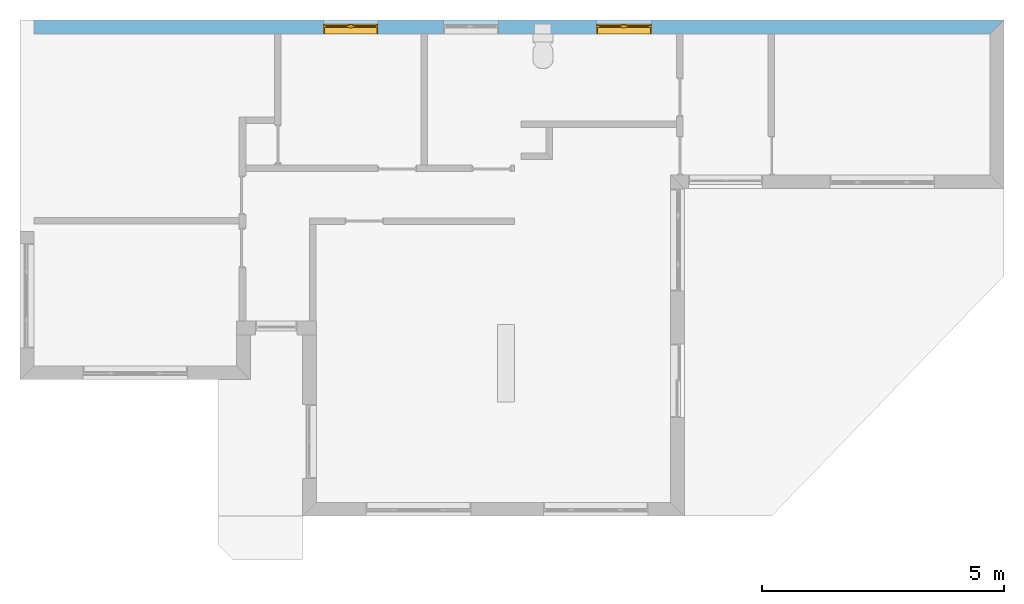
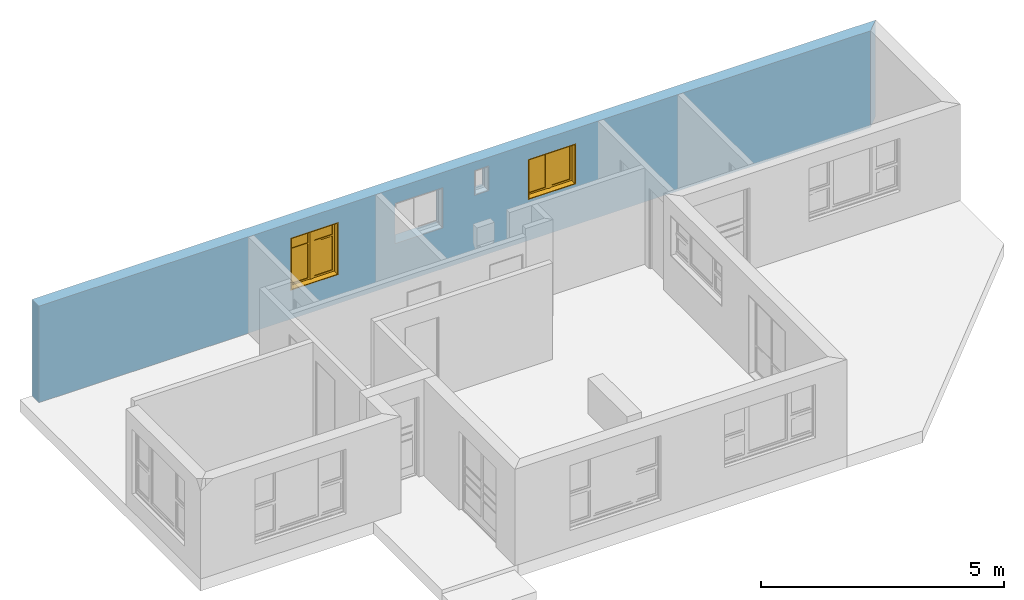
# One storey, part 14 of 15: 2 windows, 4 openings, plus 1 element that does not belong to this part.
"""IFC4 building model written with IfcOpenShell, lengths in millimetres."""

from ifc_helpers import new_model, entity, si_unit, converted_unit, frame, origin_with_axes, origin_2d_with_axis, place, context, subcontext, project, spatial, line, indexed_curve, outline, extrude, clip, halfspace, polygons, source, transform, mapped, material, layer, layer_set, layer_usage, type_object, type_shapes, element, fill, save


model = new_model("IFC4")

# Units and contexts
model_context = context("Model", 3, precision=1e-05, world=origin_with_axes())
plan_context = context("Plan", 2, precision=1e-05, world=origin_2d_with_axis())
body_context = subcontext(model_context, "Body", "Model", "MODEL_VIEW")
ifc_project = project(units=[si_unit("VOLUMEUNIT", "CUBIC_METRE"), si_unit("LENGTHUNIT", "METRE", prefix="MILLI"), converted_unit("PLANEANGLEUNIT", "degree", entity("IfcReal", 0.0174532925199433), si_unit("PLANEANGLEUNIT", "RADIAN"), dimensions=[0, 0, 0, 0, 0, 0, 0]), si_unit("AREAUNIT", "SQUARE_METRE")], contexts=[model_context, plan_context])

# Site, building, storey
site_placement = place(None, origin_with_axes())
site = spatial("IfcSite", under=ifc_project, at=site_placement)
building_placement = place(site_placement, origin_with_axes())
building = spatial("IfcBuilding", under=site, at=building_placement, Name="Building")
storey_placement = place(building_placement, origin_with_axes())
storey = spatial("IfcBuildingStorey", under=building, at=storey_placement, Name="EXISTING")

# Wall, openings, windows
ifc_material = material()
ifc_layer = layer(ifc_material, 285.0, Name="brick")
ifc_layer_set = layer_set([ifc_layer])
ifc_layer_usage = layer_usage(ifc_layer_set, "AXIS2", "POSITIVE", 0.0)
wall_type = type_object("IfcWallType", Name="285mm Wall", PredefinedType="STANDARD", material=ifc_layer_set)
wall_placement = place(storey_placement, frame((34.1207385063171, 5461.66706085205, 0.0), z_axis=(0.0, 0.0, 1.0), x_axis=(0.999999999999993, 1.19209282445353e-07, 0.0)))
wall = element("IfcWall", 1, at=wall_placement, inside=storey, type_object=wall_type, material=ifc_layer_usage, Name="Wall", context=body_context, shape_type="Clipping", body=[
    clip(extrude(outline(indexed_curve([(0.0, 0.0), (0.0, 285.0), (20070.0015485353, 285.0), (20070.0015485353, 0.0), (0.0, 0.0)], self_intersect=False)), origin_with_axes(), (0.0, 0.0, 1.0), 2425.00019073486), halfspace(frame((19785.0017547607, 2.1562527763308e-05, 0.0), z_axis=(0.707106709480286, -0.707106828689575, 0.0), x_axis=(-0.707106840791191, -0.707106721581899, 0.0)), False)),
])
shared_shape_1 = source(origin_with_axes(), body_context, "Body", "SweptSolid", [
    extrude(outline(indexed_curve([(0.0, 0.0), (340.000091552734, 0.0), (340.000091552734, 625.0), (0.0, 625.0)], segments=[line(1, 2, 3, 4, 1)])), frame((1.19209282445354e-07, -600.0, 0.0), z_axis=(0.0, -1.0, 0.0), x_axis=(1.0, 0.0, 0.0)), (0.0, 0.0, -1.0), 1200.0),
])
opening_1_placement = place(wall_placement, frame((10361.9993493649, 138.076500654373, 1585.00003814697), z_axis=(0.0, 0.0, 1.0), x_axis=(1.0, 0.0, 0.0)))
element("IfcOpeningElement", 2, at=opening_1_placement, cuts=wall, PredefinedType="OPENING", context=body_context, shape_type="MappedRepresentation", body=[
    mapped(shared_shape_1, transform((0.0, 0.0, 0.0), x_axis=(1.0, 0.0, 0.0), y_axis=(0.0, 1.0, 0.0), z_axis=(0.0, 0.0, 1.0), scale=1.0)),
])
shared_shape_2 = source(origin_with_axes(), body_context, "Body", "SweptSolid", [
    extrude(outline(indexed_curve([(0.0, 0.0), (1135.00012207031, 0.0), (1135.00012207031, 1014.99981689453), (0.0, 1014.99981689453)], segments=[line(1, 2, 3, 4, 1)])), frame((1.19209282445354e-07, -600.0, 0.0), z_axis=(0.0, -1.0, 0.0), x_axis=(1.0, 0.0, 0.0)), (0.0, 0.0, -1.0), 1200.0),
])
opening_2_placement = place(wall_placement, frame((8475.00021959052, 142.058315873181, 1030.00020980835), z_axis=(0.0, 0.0, 1.0), x_axis=(1.0, 0.0, 0.0)))
element("IfcOpeningElement", 3, at=opening_2_placement, cuts=wall, PredefinedType="OPENING", context=body_context, shape_type="MappedRepresentation", body=[
    mapped(shared_shape_2, transform((0.0, 0.0, 0.0), x_axis=(1.0, 0.0, 0.0), y_axis=(0.0, 1.0, 0.0), z_axis=(0.0, 0.0, 1.0), scale=1.0)),
])
shared_shape_3 = source(origin_with_axes(), body_context, "Body", "SweptSolid", [
    extrude(outline(indexed_curve([(0.0, 0.0), (1135.0, 0.0), (1135.0, 1321.99987792969), (0.0, 1321.99987792969)], segments=[line(1, 2, 3, 4, 1)])), frame((0.0, -600.0, -1.02445474325918e-08), z_axis=(0.0, -1.0, 0.0), x_axis=(1.0, 0.0, 0.0)), (0.0, 0.0, -1.0), 1200.0),
])
opening_3_placement = place(wall_placement, frame((5989.99865055079, 99.9991905691289, 723.000049591064), z_axis=(0.0, 0.0, 1.0), x_axis=(1.0, 0.0, 0.0)))
opening_3 = element("IfcOpeningElement", 4, at=opening_3_placement, cuts=wall, PredefinedType="OPENING", context=body_context, shape_type="MappedRepresentation", body=[
    mapped(shared_shape_3, transform((0.0, 0.0, 0.0), x_axis=(1.0, 0.0, 0.0), y_axis=(0.0, 1.0, 0.0), z_axis=(0.0, 0.0, 1.0), scale=1.0)),
])
shared_shape_4 = source(origin_with_axes(), body_context, "Body", "SweptSolid", [
    extrude(outline(indexed_curve([(0.0, 0.0), (1135.00024414062, 0.0), (1135.00024414062, 1019.99993896484), (0.0, 1019.99993896484)], segments=[line(1, 2, 3, 4, 1)])), frame((0.0, -600.0, -9.31322485797637e-09), z_axis=(0.0, -1.0, 0.0), x_axis=(1.0, 0.0, 0.0)), (0.0, 0.0, -1.0), 1200.0),
])
opening_4_placement = place(wall_placement, frame((11639.9992275636, 140.332741737542, 1025.00009536743), z_axis=(0.0, 0.0, 1.0), x_axis=(1.0, 0.0, 0.0)))
opening_4 = element("IfcOpeningElement", 5, at=opening_4_placement, cuts=wall, PredefinedType="OPENING", context=body_context, shape_type="MappedRepresentation", body=[
    mapped(shared_shape_4, transform((0.0, 0.0, 0.0), x_axis=(1.0, 0.0, 0.0), y_axis=(0.0, 1.0, 0.0), z_axis=(0.0, 0.0, 1.0), scale=1.0)),
])
window_type_1 = type_object("IfcWindowType", Name="Ex.1095x1282", PartitioningType="NOTDEFINED", PredefinedType="WINDOW")
shared_shape_5 = source(origin_with_axes(), body_context, "Body", "Tessellation", [
    polygons([(0.0, -99.9999923706055, -1.02445474112756e-05), (0.0, -99.9999923706055, 19.9999904632568), (0.0, 99.9999923706055, -1.02445474112756e-05), (0.0, 99.9999923706055, 19.9999904632568), (1134.99987792969, -99.9999923706055, -1.02445474112756e-05), (1134.99987792969, -99.9999923706055, 19.9999904632568), (1134.99987792969, 99.9999923706055, -1.02445474112756e-05), (1134.99987792969, 99.9999923706055, 19.9999904632568), (5.96046411374118e-05, -99.9999923706055, 1301.99987792969), (5.96046411374118e-05, -99.9999923706055, 1321.99987792969), (5.96046411374118e-05, 99.9999771118164, 1301.99987792969), (5.96046411374118e-05, 99.9999771118164, 1321.99987792969), (1134.99987792969, -99.9999923706055, 1301.99987792969), (1134.99987792969, -99.9999923706055, 1321.99987792969), (1134.99987792969, 99.9999771118164, 1301.99987792969), (1134.99987792969, 99.9999771118164, 1321.99987792969), (491.999938964844, 34.9999580383301, 924.999816894531), (531.999938964844, 34.9999618530273, 924.999816894531), (491.999938964844, 74.9999465942383, 924.999816894531), (531.999938964844, 74.9999618530273, 924.999816894531), (492.000122070312, 34.9999580383301, 59.9999122619629), (532.000122070312, 34.9999618530273, 59.9999122619629), (492.000122070312, 74.9999465942383, 59.9999122619629), (532.000122070312, 74.9999618530273, 59.9999122619629), (20.0000991821289, 34.9999580383301, 924.999816894531), (60.0001182556152, 34.9999618530273, 924.999816894531), (20.0000991821289, 74.9999465942383, 924.999816894531), (60.0001182556152, 74.9999618530273, 924.999816894531), (20.0002784729004, 34.9999580383301, 59.9999122619629), (60.0002975463867, 34.9999618530273, 59.9999122619629), (20.0002784729004, 74.9999465942383, 59.9999122619629), (60.0002975463867, 74.9999618530273, 59.9999122619629), (532.000183105469, 34.9999580383301, 1301.99987792969), (532.000183105469, 34.9999618530273, 1261.99987792969), (532.000183105469, 74.9999465942383, 1301.99987792969), (532.000183105469, 74.9999618530273, 1261.99987792969), (20.0002784729004, 34.9999580383301, 1301.99963378906), (20.0002784729004, 34.9999618530273, 1261.99975585938), (20.0002784729004, 74.9999465942383, 1301.99987792969), (20.0002784729004, 74.9999618530273, 1261.99975585938), (641.999877929688, 49.9999580383301, 914.999694824219), (1075.0, 49.9999618530273, 914.999694824219), (641.999877929688, 59.9999504089355, 914.999694824219), (1075.0, 59.9999580383301, 914.999694824219), (642.000061035156, 49.9999580383301, 59.9999122619629), (1075.00024414062, 49.9999618530273, 59.9999122619629), (642.000061035156, 59.9999504089355, 59.9999122619629), (1075.00024414062, 59.9999580383301, 59.9999122619629), (0.000238418564549647, -99.9999923706055, 1301.99987792969), (20.0002174377441, -99.9999923706055, 1301.99987792969), (0.000238418564549647, 99.9999771118164, 1301.99987792969), (20.0002174377441, 99.9999771118164, 1301.99987792969), (0.000417232484323904, -99.9999923706055, 20.0000286102295), (20.0004558563232, -99.9999923706055, 20.0000286102295), (0.000417232484323904, 99.9999771118164, 20.0000286102295), (20.0004558563232, 99.9999771118164, 20.0000286102295), (532.0, 19.9999561309814, 1301.99987792969), (601.999938964844, 19.9999694824219, 1301.99987792969), (532.0, 89.9999465942383, 1301.99987792969), (601.999938964844, 89.9999618530273, 1301.99987792969), (532.000122070312, 19.9999561309814, 20.0000286102295), (602.000122070312, 19.9999694824219, 20.0000286102295), (532.000122070312, 89.9999465942383, 20.0000286102295), (602.000122070312, 89.9999618530273, 20.0000286102295), (1115.0, -99.9999923706055, 1301.99987792969), (1134.99987792969, -99.9999923706055, 1301.99987792969), (1115.0, 99.9999771118164, 1301.99987792969), (1134.99987792969, 99.9999771118164, 1301.99987792969), (1115.00012207031, -99.9999923706055, 20.0000286102295), (1135.00012207031, -99.9999923706055, 20.0000286102295), (1115.00012207031, 99.9999771118164, 20.0000286102295), (1135.00012207031, 99.9999771118164, 20.0000286102295), (1075.0, 34.9999580383301, 914.999694824219), (1115.0, 34.9999618530273, 914.999694824219), (1075.0, 74.9999465942383, 914.999694824219), (1115.0, 74.9999618530273, 914.999694824219), (1075.00024414062, 34.9999580383301, 59.9999122619629), (1115.00012207031, 34.9999618530273, 59.9999122619629), (1075.00024414062, 74.9999465942383, 59.9999122619629), (1115.00012207031, 74.9999618530273, 59.9999122619629), (602.0, 34.9999580383301, 914.999694824219), (642.000061035156, 34.9999618530273, 914.999694824219), (602.0, 74.9999465942383, 914.999694824219), (642.000061035156, 74.9999618530273, 914.999694824219), (602.000183105469, 34.9999580383301, 59.9999122619629), (642.000244140625, 34.9999618530273, 59.9999122619629), (602.000183105469, 74.9999465942383, 59.9999122619629), (642.000244140625, 74.9999618530273, 59.9999122619629), (532.000183105469, 34.9999580383301, 59.9999809265137), (532.000183105469, 34.9999618530273, 19.9999809265137), (532.000183105469, 74.9999465942383, 59.9999847412109), (532.000183105469, 74.9999618530273, 19.9999866485596), (20.0002784729004, 34.9999580383301, 59.9998359680176), (20.0002784729004, 34.9999618530273, 19.9998321533203), (20.0002784729004, 74.9999465942383, 59.9998397827148), (20.0002784729004, 74.9999618530273, 19.9998397827148), (1115.00012207031, 34.9999580383301, 59.9999809265137), (1115.00012207031, 34.9999618530273, 19.999979019165), (1115.00012207031, 74.9999465942383, 59.9999809265137), (1115.00012207031, 74.9999618530273, 19.9999866485596), (602.000183105469, 34.9999580383301, 59.999828338623), (602.000183105469, 34.9999618530273, 19.9998321533203), (602.000183105469, 74.9999465942383, 59.9998397827148), (602.000183105469, 74.9999618530273, 19.9998378753662), (1115.00012207031, 34.9999580383301, 1301.99987792969), (1115.00012207031, 34.9999618530273, 1261.99987792969), (1115.00012207031, 74.9999465942383, 1301.99987792969), (1115.00012207031, 74.9999618530273, 1261.99987792969), (602.000183105469, 34.9999580383301, 1301.99963378906), (602.000183105469, 34.9999618530273, 1261.99975585938), (602.000183105469, 74.9999465942383, 1301.99987792969), (602.000183105469, 74.9999618530273, 1261.99975585938), (60.0001792907715, 49.9999580383301, 924.999816894531), (491.999938964844, 49.9999618530273, 924.999816894531), (60.0001792907715, 59.9999504089355, 924.999816894531), (491.999938964844, 59.9999580383301, 924.999816894531), (60.0003547668457, 49.9999580383301, 59.9999122619629), (492.000122070312, 49.9999618530273, 59.9999122619629), (60.0003547668457, 59.9999504089355, 59.9999122619629), (492.000122070312, 59.9999580383301, 59.9999122619629), (1115.00012207031, 34.9999580383301, 954.999877929688), (1115.00012207031, 34.9999618530273, 914.999816894531), (1115.00012207031, 74.9999465942383, 954.999877929688), (1115.00012207031, 74.9999618530273, 914.999816894531), (602.000183105469, 34.9999580383301, 954.999694824219), (602.000183105469, 34.9999618530273, 914.999694824219), (602.000183105469, 74.9999465942383, 954.999694824219), (602.000183105469, 74.9999618530273, 914.999694824219), (533.000061035156, 34.9999618530273, 944.999755859375), (533.000061035156, 34.9999656677246, 924.999816894531), (533.000061035156, 74.9999542236328, 944.999755859375), (533.000061035156, 74.9999618530273, 924.999816894531), (20.0001583099365, 34.9999618530273, 944.999694824219), (20.0001583099365, 34.9999656677246, 924.999694824219), (20.0001583099365, 74.9999542236328, 944.999694824219), (20.0001583099365, 74.9999618530273, 924.999694824219), (602.0, 34.9999580383301, 1261.99975585938), (642.000061035156, 34.9999618530273, 1261.99975585938), (602.0, 74.9999465942383, 1261.99975585938), (642.000061035156, 74.9999618530273, 1261.99975585938), (602.000183105469, 34.9999580383301, 954.999755859375), (642.000244140625, 34.9999618530273, 954.999877929688), (602.000183105469, 74.9999465942383, 954.999755859375), (642.000244140625, 74.9999618530273, 954.999877929688), (1074.99975585938, 34.9999580383301, 1261.99975585938), (1114.99975585938, 34.9999618530273, 1261.99975585938), (1074.99975585938, 74.9999465942383, 1261.99975585938), (1114.99975585938, 74.9999618530273, 1261.99975585938), (1075.0, 34.9999580383301, 954.999755859375), (1115.0, 34.9999618530273, 954.999877929688), (1075.0, 74.9999465942383, 954.999755859375), (1115.0, 74.9999618530273, 954.999877929688), (20.0000991821289, 34.9999580383301, 1261.99975585938), (60.0001182556152, 34.9999618530273, 1261.99975585938), (20.0000991821289, 74.9999465942383, 1261.99975585938), (60.0001182556152, 74.9999618530273, 1261.99975585938), (20.0002784729004, 34.9999580383301, 944.999755859375), (60.0002975463867, 34.9999618530273, 944.999755859375), (20.0002784729004, 74.9999465942383, 944.999755859375), (60.0002975463867, 74.9999618530273, 944.999755859375), (491.999938964844, 34.9999580383301, 1261.99975585938), (531.999938964844, 34.9999618530273, 1261.99975585938), (491.999938964844, 74.9999465942383, 1261.99975585938), (531.999938964844, 74.9999618530273, 1261.99975585938), (492.000122070312, 34.9999580383301, 944.999755859375), (532.000122070312, 34.9999618530273, 944.999755859375), (492.000122070312, 74.9999465942383, 944.999755859375), (532.000122070312, 74.9999618530273, 944.999755859375), (60.0001792907715, 49.9999580383301, 1261.99975585938), (491.999938964844, 49.9999618530273, 1261.99975585938), (60.0001792907715, 59.9999504089355, 1261.99975585938), (491.999938964844, 59.9999580383301, 1261.99975585938), (60.000415802002, 49.9999580383301, 944.999755859375), (492.000122070312, 49.9999618530273, 944.999755859375), (60.000415802002, 59.9999504089355, 944.999755859375), (492.000122070312, 59.9999580383301, 944.999755859375), (641.999877929688, 49.9999580383301, 1261.99975585938), (1075.0, 49.9999618530273, 1261.99975585938), (641.999877929688, 59.9999504089355, 1261.99975585938), (1075.0, 59.9999580383301, 1261.99975585938), (642.000061035156, 49.9999580383301, 954.999694824219), (1075.00024414062, 49.9999618530273, 954.999755859375), (642.000061035156, 59.9999504089355, 954.999694824219), (1075.00024414062, 59.9999580383301, 954.999755859375)], [[[1, 2, 4, 3]], [[3, 4, 8, 7]], [[7, 8, 6, 5]], [[5, 6, 2, 1]], [[3, 7, 5, 1]], [[8, 4, 2, 6]], [[9, 10, 12, 11]], [[11, 12, 16, 15]], [[15, 16, 14, 13]], [[13, 14, 10, 9]], [[11, 15, 13, 9]], [[16, 12, 10, 14]], [[17, 18, 20, 19]], [[19, 20, 24, 23]], [[23, 24, 22, 21]], [[21, 22, 18, 17]], [[19, 23, 21, 17]], [[24, 20, 18, 22]], [[25, 26, 28, 27]], [[27, 28, 32, 31]], [[31, 32, 30, 29]], [[29, 30, 26, 25]], [[27, 31, 29, 25]], [[32, 28, 26, 30]], [[33, 34, 36, 35]], [[35, 36, 40, 39]], [[39, 40, 38, 37]], [[37, 38, 34, 33]], [[35, 39, 37, 33]], [[40, 36, 34, 38]], [[41, 42, 44, 43]], [[43, 44, 48, 47]], [[47, 48, 46, 45]], [[45, 46, 42, 41]], [[43, 47, 45, 41]], [[48, 44, 42, 46]], [[49, 50, 52, 51]], [[51, 52, 56, 55]], [[55, 56, 54, 53]], [[53, 54, 50, 49]], [[51, 55, 53, 49]], [[56, 52, 50, 54]], [[57, 58, 60, 59]], [[59, 60, 64, 63]], [[63, 64, 62, 61]], [[61, 62, 58, 57]], [[59, 63, 61, 57]], [[64, 60, 58, 62]], [[65, 66, 68, 67]], [[67, 68, 72, 71]], [[71, 72, 70, 69]], [[69, 70, 66, 65]], [[67, 71, 69, 65]], [[72, 68, 66, 70]], [[73, 74, 76, 75]], [[75, 76, 80, 79]], [[79, 80, 78, 77]], [[77, 78, 74, 73]], [[75, 79, 77, 73]], [[80, 76, 74, 78]], [[81, 82, 84, 83]], [[83, 84, 88, 87]], [[87, 88, 86, 85]], [[85, 86, 82, 81]], [[83, 87, 85, 81]], [[88, 84, 82, 86]], [[89, 90, 92, 91]], [[91, 92, 96, 95]], [[95, 96, 94, 93]], [[93, 94, 90, 89]], [[91, 95, 93, 89]], [[96, 92, 90, 94]], [[97, 98, 100, 99]], [[99, 100, 104, 103]], [[103, 104, 102, 101]], [[101, 102, 98, 97]], [[99, 103, 101, 97]], [[104, 100, 98, 102]], [[105, 106, 108, 107]], [[107, 108, 112, 111]], [[111, 112, 110, 109]], [[109, 110, 106, 105]], [[107, 111, 109, 105]], [[112, 108, 106, 110]], [[113, 114, 116, 115]], [[115, 116, 120, 119]], [[119, 120, 118, 117]], [[117, 118, 114, 113]], [[115, 119, 117, 113]], [[120, 116, 114, 118]], [[121, 122, 124, 123]], [[123, 124, 128, 127]], [[127, 128, 126, 125]], [[125, 126, 122, 121]], [[123, 127, 125, 121]], [[128, 124, 122, 126]], [[129, 130, 132, 131]], [[131, 132, 136, 135]], [[135, 136, 134, 133]], [[133, 134, 130, 129]], [[131, 135, 133, 129]], [[136, 132, 130, 134]], [[137, 138, 140, 139]], [[139, 140, 144, 143]], [[143, 144, 142, 141]], [[141, 142, 138, 137]], [[139, 143, 141, 137]], [[144, 140, 138, 142]], [[145, 146, 148, 147]], [[147, 148, 152, 151]], [[151, 152, 150, 149]], [[149, 150, 146, 145]], [[147, 151, 149, 145]], [[152, 148, 146, 150]], [[153, 154, 156, 155]], [[155, 156, 160, 159]], [[159, 160, 158, 157]], [[157, 158, 154, 153]], [[155, 159, 157, 153]], [[160, 156, 154, 158]], [[161, 162, 164, 163]], [[163, 164, 168, 167]], [[167, 168, 166, 165]], [[165, 166, 162, 161]], [[163, 167, 165, 161]], [[168, 164, 162, 166]], [[169, 170, 172, 171]], [[171, 172, 176, 175]], [[175, 176, 174, 173]], [[173, 174, 170, 169]], [[171, 175, 173, 169]], [[176, 172, 170, 174]], [[177, 178, 180, 179]], [[179, 180, 184, 183]], [[183, 184, 182, 181]], [[181, 182, 178, 177]], [[179, 183, 181, 177]], [[184, 180, 178, 182]]], closed=True),
])
type_shapes(window_type_1, [shared_shape_5])
window_1_placement = place(opening_3_placement, frame((-2.66453525910038e-12, 0.0, 4.44089209850063e-13), z_axis=(0.0, 0.0, 1.0), x_axis=(1.0, 3.97046694025453e-23, 0.0)))
window_1 = element("IfcWindow", 6, at=window_1_placement, inside=storey, type_object=window_type_1, Name="Window", context=body_context, shape_type="MappedRepresentation", body=[
    mapped(shared_shape_5, transform((0.0, 0.0, 0.0), x_axis=(1.0, 0.0, 0.0), y_axis=(0.0, 1.0, 0.0), z_axis=(0.0, 0.0, 1.0), scale=1.0)),
])
fill(opening_3, window_1)
window_type_2 = type_object("IfcWindowType", Name="Ex.1095x980", PartitioningType="NOTDEFINED", PredefinedType="WINDOW")
shared_shape_6 = source(origin_with_axes(), body_context, "Body", "Tessellation", [
    polygons([(0.0, -140.333312988281, -9.31322483666008e-06), (0.0, -140.333312988281, 19.9999904632568), (0.0, 59.666675567627, -9.31322483666008e-06), (0.0, 59.666675567627, 19.9999904632568), (1135.00024414062, -140.333312988281, -9.31322483666008e-06), (1135.00024414062, -140.333312988281, 19.9999904632568), (1135.00024414062, 59.666675567627, -9.31322483666008e-06), (1135.00024414062, 59.666675567627, 19.9999904632568), (0.000238418564549647, -140.333312988281, 1000.00006103516), (0.000238418564549647, -140.333312988281, 1019.99993896484), (0.000238418564549647, 59.666675567627, 1000.00006103516), (0.000238418564549647, 59.666675567627, 1019.99993896484), (1135.00012207031, -140.333312988281, 1000.00006103516), (1135.00012207031, -140.333312988281, 1019.99993896484), (1135.00012207031, 59.666675567627, 1000.00006103516), (1135.00012207031, 59.666675567627, 1019.99993896484), (0.0, -140.333312988281, 19.9999904632568), (0.0, -140.333312988281, 1000.00006103516), (0.0, 59.666675567627, 19.9999904632568), (0.0, 59.666675567627, 1000.00006103516), (20.0002174377441, -140.333312988281, 19.9999904632568), (20.0002174377441, -140.333312988281, 1000.00006103516), (20.0002174377441, 59.666675567627, 19.9999904632568), (20.0002174377441, 59.666675567627, 1000.00006103516), (1115.00012207031, -140.333312988281, 19.9999904632568), (1115.00012207031, -140.333312988281, 1000.00006103516), (1115.00012207031, 59.666675567627, 19.9999904632568), (1115.00012207031, 59.666675567627, 1000.00006103516), (1135.00036621094, -140.333312988281, 19.9999904632568), (1135.00036621094, -140.333312988281, 1000.00006103516), (1135.00036621094, 59.666675567627, 19.9999904632568), (1135.00036621094, 59.666675567627, 1000.00006103516), (532.000244140625, -20.3333377838135, 19.9999542236328), (532.000244140625, -20.3333377838135, 1000.00006103516), (532.000244140625, 49.6666641235352, 19.9999542236328), (532.000244140625, 49.6666641235352, 1000.00006103516), (602.000183105469, -20.3333377838135, 19.9999542236328), (602.000183105469, -20.3333377838135, 1000.00006103516), (602.000183105469, 49.6666641235352, 19.9999542236328), (602.000183105469, 49.6666641235352, 1000.00006103516), (20.0002174377441, -5.33334112167358, 59.9999542236328), (20.0002174377441, -5.33334112167358, 960.000061035156), (20.0002174377441, 34.6666717529297, 59.9999542236328), (20.0002174377441, 34.6666717529297, 960.000061035156), (59.9999389648438, -5.33334112167358, 59.9999542236328), (59.9999389648438, -5.33334112167358, 960.000061035156), (59.9999389648438, 34.6666717529297, 59.9999542236328), (59.9999389648438, 34.6666717529297, 960.000061035156), (492.000183105469, -5.33334112167358, 59.9999542236328), (492.000183105469, -5.33334112167358, 960.000061035156), (492.000183105469, 34.6666717529297, 59.9999542236328), (492.000183105469, 34.6666717529297, 960.000061035156), (532.000244140625, -5.33334112167358, 59.9999542236328), (532.000244140625, -5.33334112167358, 960.000061035156), (532.000244140625, 34.6666717529297, 59.9999542236328), (532.000244140625, 34.6666717529297, 960.000061035156), (602.000183105469, -5.33334112167358, 59.9999542236328), (602.000183105469, -5.33334112167358, 960.000061035156), (602.000183105469, 34.6666717529297, 59.9999542236328), (602.000183105469, 34.6666717529297, 960.000061035156), (642.000305175781, -5.33334112167358, 59.9999542236328), (642.000305175781, -5.33334112167358, 960.000061035156), (642.000305175781, 34.6666717529297, 59.9999542236328), (642.000305175781, 34.6666717529297, 960.000061035156), (1075.00024414062, -5.33334112167358, 59.9999542236328), (1075.00024414062, -5.33334112167358, 960.000061035156), (1075.00024414062, 34.6666717529297, 59.9999542236328), (1075.00024414062, 34.6666717529297, 960.000061035156), (1115.00012207031, -5.33334112167358, 59.9999542236328), (1115.00012207031, -5.33334112167358, 960.000061035156), (1115.00012207031, 34.6666717529297, 59.9999542236328), (1115.00012207031, 34.6666717529297, 960.000061035156), (20.0002174377441, -5.33334112167358, 19.9999904632568), (20.0002174377441, -5.33334112167358, 59.9999923706055), (20.0002174377441, 34.6666717529297, 19.9999904632568), (20.0002174377441, 34.6666717529297, 59.9999923706055), (532.000061035156, -5.33334112167358, 19.9999904632568), (532.000061035156, -5.33334112167358, 59.9999923706055), (532.000061035156, 34.6666717529297, 19.9999904632568), (532.000061035156, 34.6666717529297, 59.9999923706055), (602.000183105469, -5.33334112167358, 19.9999904632568), (602.000183105469, -5.33334112167358, 59.9999923706055), (602.000183105469, 34.6666717529297, 19.9999904632568), (602.000183105469, 34.6666717529297, 59.9999923706055), (1115.0, -5.33334112167358, 19.9999904632568), (1115.0, -5.33334112167358, 59.9999923706055), (1115.0, 34.6666717529297, 19.9999904632568), (1115.0, 34.6666717529297, 59.9999923706055), (20.0002174377441, -5.33334112167358, 960.000061035156), (20.0002174377441, -5.33334112167358, 1000.00006103516), (20.0002174377441, 34.6666717529297, 960.000061035156), (20.0002174377441, 34.6666717529297, 1000.00006103516), (532.000061035156, -5.33334112167358, 960.000061035156), (532.000061035156, -5.33334112167358, 1000.00006103516), (532.000061035156, 34.6666717529297, 960.000061035156), (532.000061035156, 34.6666717529297, 1000.00006103516), (602.000183105469, -5.33334112167358, 960.000061035156), (602.000183105469, -5.33334112167358, 1000.00006103516), (602.000183105469, 34.6666717529297, 960.000061035156), (602.000183105469, 34.6666717529297, 1000.00006103516), (1115.0, -5.33334112167358, 960.000061035156), (1115.0, -5.33334112167358, 1000.00006103516), (1115.0, 34.6666717529297, 960.000061035156), (1115.0, 34.6666717529297, 1000.00006103516), (60.0001792907715, 9.66665840148926, 59.9999542236328), (60.0001792907715, 9.66665840148926, 960.000061035156), (60.0001792907715, 19.6666622161865, 59.9999542236328), (60.0001792907715, 19.6666622161865, 960.000061035156), (492.000183105469, 9.66665840148926, 59.9999542236328), (492.000183105469, 9.66665840148926, 960.000061035156), (492.000183105469, 19.6666622161865, 59.9999542236328), (492.000183105469, 19.6666622161865, 960.000061035156), (642.000183105469, 9.66665840148926, 59.9999542236328), (642.000183105469, 9.66665840148926, 960.000061035156), (642.000183105469, 19.6666622161865, 59.9999542236328), (642.000183105469, 19.6666622161865, 960.000061035156), (1075.00036621094, 9.66665840148926, 59.9999542236328), (1075.00036621094, 9.66665840148926, 960.000061035156), (1075.00036621094, 19.6666622161865, 59.9999542236328), (1075.00036621094, 19.6666622161865, 960.000061035156)], [[[1, 2, 4, 3]], [[3, 4, 8, 7]], [[7, 8, 6, 5]], [[5, 6, 2, 1]], [[3, 7, 5, 1]], [[8, 4, 2, 6]], [[9, 10, 12, 11]], [[11, 12, 16, 15]], [[15, 16, 14, 13]], [[13, 14, 10, 9]], [[11, 15, 13, 9]], [[16, 12, 10, 14]], [[17, 18, 20, 19]], [[19, 20, 24, 23]], [[23, 24, 22, 21]], [[21, 22, 18, 17]], [[19, 23, 21, 17]], [[24, 20, 18, 22]], [[25, 26, 28, 27]], [[27, 28, 32, 31]], [[31, 32, 30, 29]], [[29, 30, 26, 25]], [[27, 31, 29, 25]], [[32, 28, 26, 30]], [[33, 34, 36, 35]], [[35, 36, 40, 39]], [[39, 40, 38, 37]], [[37, 38, 34, 33]], [[35, 39, 37, 33]], [[40, 36, 34, 38]], [[41, 42, 44, 43]], [[43, 44, 48, 47]], [[47, 48, 46, 45]], [[45, 46, 42, 41]], [[43, 47, 45, 41]], [[48, 44, 42, 46]], [[49, 50, 52, 51]], [[51, 52, 56, 55]], [[55, 56, 54, 53]], [[53, 54, 50, 49]], [[51, 55, 53, 49]], [[56, 52, 50, 54]], [[57, 58, 60, 59]], [[59, 60, 64, 63]], [[63, 64, 62, 61]], [[61, 62, 58, 57]], [[59, 63, 61, 57]], [[64, 60, 58, 62]], [[65, 66, 68, 67]], [[67, 68, 72, 71]], [[71, 72, 70, 69]], [[69, 70, 66, 65]], [[67, 71, 69, 65]], [[72, 68, 66, 70]], [[73, 74, 76, 75]], [[75, 76, 80, 79]], [[79, 80, 78, 77]], [[77, 78, 74, 73]], [[75, 79, 77, 73]], [[80, 76, 74, 78]], [[81, 82, 84, 83]], [[83, 84, 88, 87]], [[87, 88, 86, 85]], [[85, 86, 82, 81]], [[83, 87, 85, 81]], [[88, 84, 82, 86]], [[89, 90, 92, 91]], [[91, 92, 96, 95]], [[95, 96, 94, 93]], [[93, 94, 90, 89]], [[91, 95, 93, 89]], [[96, 92, 90, 94]], [[97, 98, 100, 99]], [[99, 100, 104, 103]], [[103, 104, 102, 101]], [[101, 102, 98, 97]], [[99, 103, 101, 97]], [[104, 100, 98, 102]], [[105, 106, 108, 107]], [[107, 108, 112, 111]], [[111, 112, 110, 109]], [[109, 110, 106, 105]], [[107, 111, 109, 105]], [[112, 108, 106, 110]], [[113, 114, 116, 115]], [[115, 116, 120, 119]], [[119, 120, 118, 117]], [[117, 118, 114, 113]], [[115, 119, 117, 113]], [[120, 116, 114, 118]]], closed=True),
])
type_shapes(window_type_2, [shared_shape_6])
window_2_placement = place(opening_4_placement, frame((-4.79616346638068e-11, 0.0, 1.55431223447522e-12), z_axis=(0.0, 0.0, 1.0), x_axis=(1.0, 3.97046694025453e-23, 0.0)))
window_2 = element("IfcWindow", 7, at=window_2_placement, inside=storey, type_object=window_type_2, Name="Window", context=body_context, shape_type="MappedRepresentation", body=[
    mapped(shared_shape_6, transform((0.0, 0.0, 0.0), x_axis=(1.0, 0.0, 0.0), y_axis=(0.0, 1.0, 0.0), z_axis=(0.0, 0.0, 1.0), scale=1.0)),
])
fill(opening_4, window_2)

save(model, "model.ifc")
